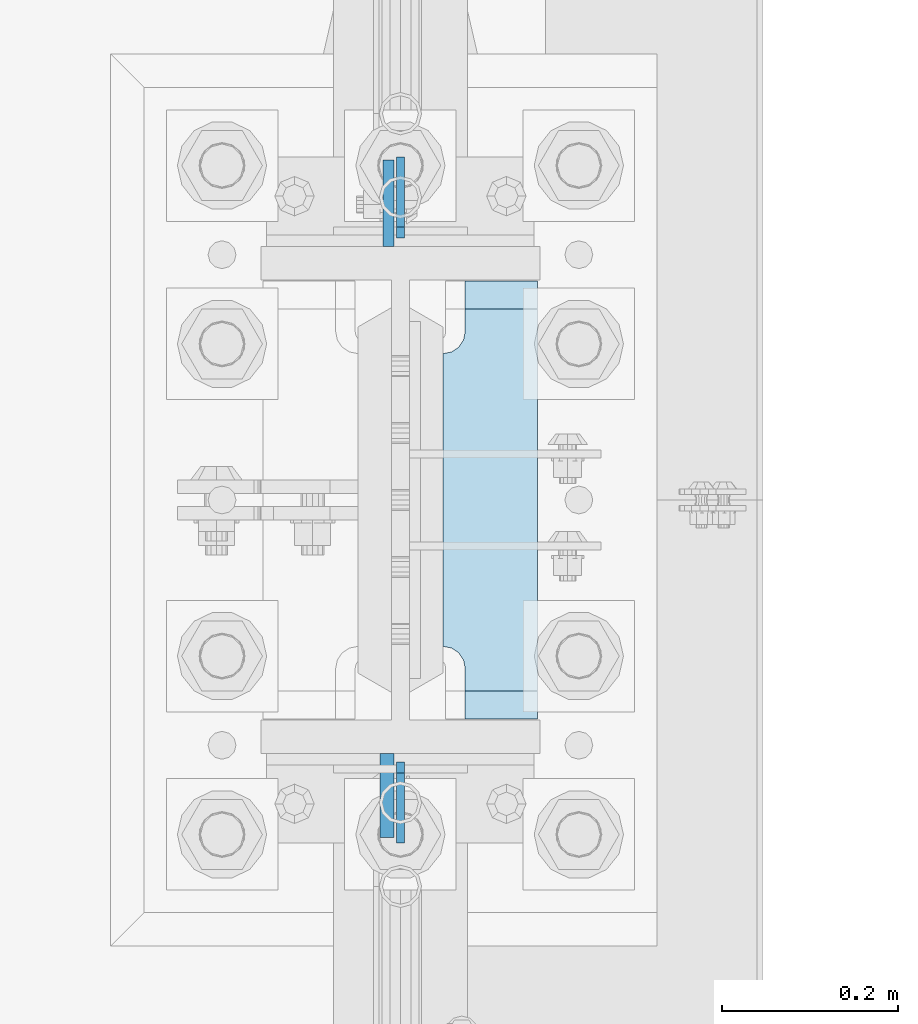
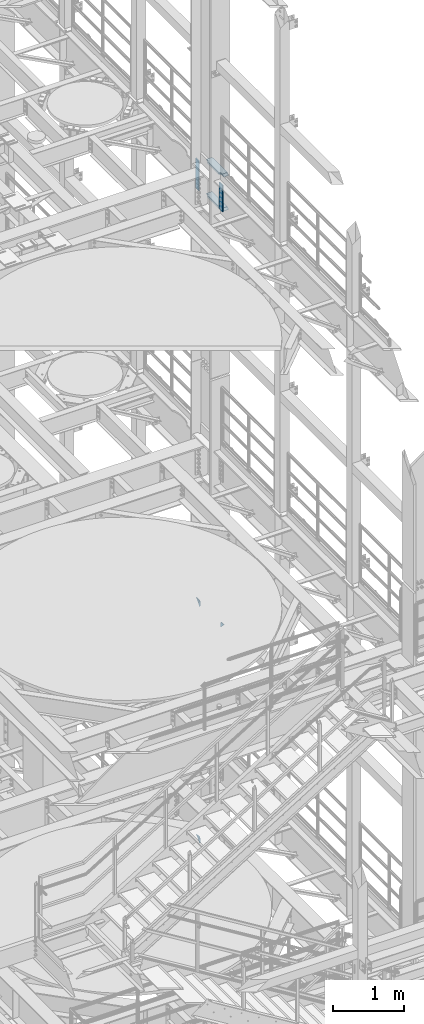
# One storey, part 1674 of 1876: 7 plates, 2 elements without a shape of their own.
"""IFC2X3 building model written with IfcOpenShell, lengths in millimetres."""

from ifc_helpers import new_model, si_unit, frame, origin_with_axes, place, context, subcontext, project, spatial, faceted_brep, material, type_object, element, aggregate, save


model = new_model("IFC2X3")

# Units and contexts
model_context = context("Model", 3, precision=1e-05, world=origin_with_axes())
body_context = subcontext(model_context, "Body", "Model", "MODEL_VIEW")
ifc_project = project(units=[si_unit("LENGTHUNIT", "METRE", prefix="MILLI"), si_unit("AREAUNIT", "SQUARE_METRE"), si_unit("VOLUMEUNIT", "CUBIC_METRE"), si_unit("MASSUNIT", "GRAM", prefix="KILO"), si_unit("TIMEUNIT", "SECOND"), si_unit("PLANEANGLEUNIT", "RADIAN"), si_unit("SOLIDANGLEUNIT", "STERADIAN"), si_unit("THERMODYNAMICTEMPERATUREUNIT", "DEGREE_CELSIUS"), si_unit("LUMINOUSINTENSITYUNIT", "LUMEN")], contexts=[model_context])

# Site, building, storey
site_placement = place(None, origin_with_axes())
site = spatial("IfcSite", under=ifc_project, at=site_placement, CompositionType="ELEMENT")
building_placement = place(site_placement, origin_with_axes())
building = spatial("IfcBuilding", under=site, at=building_placement, Name="Undefined", CompositionType="ELEMENT")
storey_placement = place(building_placement, origin_with_axes())
storey = spatial("IfcBuildingStorey", under=building, at=storey_placement, Name="Undefined", CompositionType="ELEMENT", Elevation=0.0)

# Assembly, plates
assembly_1_placement = place(storey_placement, origin_with_axes())
assembly_1 = element("IfcElementAssembly", 1, at=assembly_1_placement, inside=storey, Name="COLUMN", AssemblyPlace="NOTDEFINED", PredefinedType="RIGID_FRAME")
ifc_material_1 = material(Name="STEEL/A36")
plate_type_1 = type_object("IfcPlateType", PredefinedType="NOTDEFINED")
plate_1_placement = place(assembly_1_placement, frame((7620.0, 1133.47499940317, 10325.1), z_axis=(0.0, 0.707106781186548, 0.707106781186548), x_axis=(0.0, 0.707106781186548, -0.707106781186548)))
plate_1 = element("IfcPlate", 2, at=plate_1_placement, type_object=plate_type_1, material=ifc_material_1, Name="PLATE", context=body_context, shape_type="Brep", body=[
    faceted_brep([(0.0, -4.76249999999982, 0.0), (56.1266013136901, -4.76249999997708, 56.1266013135391), (56.1266013136883, 4.76250000002256, 56.1266013135428), (0.0, 4.76249999999982, 0.0), (74.0871132860975, -4.7624999999698, 56.1266013135246), (74.0871132860993, 4.76250000002983, 56.1266013135282), (130.213714599717, -4.76249999994707, -1.30967237055302e-10), (130.213714599715, 4.76250000005257, -1.23691279441118e-10)], [[[0, 1, 2, 3]], [[1, 4, 5, 2]], [[4, 6, 7, 5]], [[6, 0, 3, 7]], [[5, 7, 3, 2]], [[6, 4, 1, 0]]]),
])
plate_2_placement = place(assembly_1_placement, frame((7620.0, 1914.52500059683, 10325.1), z_axis=(0.0, -0.707106781186548, 0.707106781186548), x_axis=(0.0, -0.707106781186548, -0.707106781186548)))
plate_2 = element("IfcPlate", 3, at=plate_2_placement, type_object=plate_type_1, material=ifc_material_1, Name="PLATE", context=body_context, shape_type="Brep", body=[
    faceted_brep([(0.0, -4.76249999999982, 0.0), (56.1266013136901, -4.76249999997708, 56.1266013135391), (56.1266013136883, 4.76250000002256, 56.1266013135428), (0.0, 4.76249999999982, 0.0), (74.0871132860975, -4.7624999999698, 56.1266013135246), (74.0871132860993, 4.76250000002983, 56.1266013135282), (130.213714599717, -4.76249999994707, -1.30967237055302e-10), (130.213714599715, 4.76250000005257, -1.23691279441118e-10)], [[[0, 1, 2, 3]], [[1, 4, 5, 2]], [[4, 6, 7, 5]], [[6, 0, 3, 7]], [[5, 7, 3, 2]], [[6, 4, 1, 0]]]),
])
plate_3_placement = place(assembly_1_placement, frame((7620.0, 1914.52500059683, 6235.7), z_axis=(0.0, -0.707106781186548, 0.707106781186548), x_axis=(0.0, -0.707106781186548, -0.707106781186548)))
plate_3 = element("IfcPlate", 4, at=plate_3_placement, type_object=plate_type_1, material=ifc_material_1, Name="PLATE", context=body_context, shape_type="Brep", body=[
    faceted_brep([(0.0, -4.76249999999982, 0.0), (56.1266013136901, -4.76249999997708, 56.1266013135391), (56.1266013136883, 4.76250000002256, 56.1266013135428), (0.0, 4.76249999999982, 0.0), (74.0871132860975, -4.7624999999698, 56.1266013135246), (74.0871132860993, 4.76250000002983, 56.1266013135282), (130.213714599717, -4.76249999994707, -1.30967237055302e-10), (130.213714599715, 4.76250000005257, -1.23691279441118e-10)], [[[0, 1, 2, 3]], [[1, 4, 5, 2]], [[4, 6, 7, 5]], [[6, 0, 3, 7]], [[5, 7, 3, 2]], [[6, 4, 1, 0]]]),
])
aggregate(assembly_1, [plate_1, plate_2, plate_3])

assembly_2_placement = place(storey_placement, origin_with_axes())
assembly_2 = element("IfcElementAssembly", 5, at=assembly_2_placement, inside=storey, Name="COLUMN", AssemblyPlace="NOTDEFINED", PredefinedType="RIGID_FRAME")
ifc_material_2 = material(Name="STEEL/A572-50")
plate_type_2 = type_object("IfcPlateType", PredefinedType="NOTDEFINED")
plate_4_placement = place(assembly_2_placement, frame((7606.50699987411, 1812.925, 17929.225), z_axis=(0.0, 1.0, 0.0), x_axis=(0.0, 0.0, -1.0)))
plate_4 = element("IfcPlate", 6, at=plate_4_placement, type_object=plate_type_2, material=ifc_material_2, Name="PLATE", context=body_context, shape_type="Brep", body=[
    faceted_brep([(0.0, -6.35000000000036, 0.0), (0.0, -6.34999999999991, 98.4250030517578), (0.0, 6.34999999999991, 98.4250030517578), (0.0, 6.35000000000036, 0.0), (514.349975585938, -6.35000000000036, 98.4250030517578), (514.349975585938, 6.35000000000036, 98.4250030517578), (514.349975585938, -6.35000000000036, 0.0), (514.349975585938, 6.35000000000036, 0.0)], [[[0, 1, 2, 3]], [[1, 4, 5, 2]], [[4, 6, 7, 5]], [[6, 0, 3, 7]], [[5, 7, 3, 2]], [[6, 4, 1, 0]]]),
])
plate_type_3 = type_object("IfcPlateType", PredefinedType="NOTDEFINED")
plate_5_placement = place(assembly_2_placement, frame((7604.91949987411, 1235.075, 17919.7), z_axis=(0.0, -1.0, 0.0), x_axis=(0.0, 0.0, -1.0)))
plate_5 = element("IfcPlate", 7, at=plate_5_placement, type_object=plate_type_3, material=ifc_material_2, Name="PLATE", context=body_context, shape_type="Brep", body=[
    faceted_brep([(0.0, -7.9375, 0.0), (0.0, -7.9375, 95.25), (0.0, 7.9375, 95.25), (0.0, 7.9375, 0.0), (457.200012207031, -7.9375, 95.25), (457.200012207031, 7.9375, 95.25), (457.200012207031, -7.9375, 0.0), (457.200012207031, 7.9375, 0.0)], [[[0, 1, 2, 3]], [[1, 4, 5, 2]], [[4, 6, 7, 5]], [[6, 0, 3, 7]], [[5, 7, 3, 2]], [[6, 4, 1, 0]]]),
])
plate_type_4 = type_object("IfcPlateType", PredefinedType="NOTDEFINED")
plate_6_placement = place(assembly_2_placement, frame((7668.41875, 1773.2375, 17376.775012207), z_axis=(0.0, -1.0, 0.0), x_axis=(1.0, 0.0, 0.0)))
plate_6 = element("IfcPlate", 8, at=plate_6_placement, type_object=plate_type_4, material=ifc_material_2, Name="PLATE", context=body_context, shape_type="Brep", body=[
    faceted_brep([(107.949996948242, -15.875, 498.475006103516), (107.949996948242, 15.875, 467.025007631571), (25.3999996185303, 15.875, 467.025007631571), (25.3999996185303, -15.875, 498.475006103516), (23.4665397733561, -15.875, 431.604843634198), (25.3999996185303, -15.875, 441.325002670288), (25.3999996185303, 15.875, 441.325002670288), (23.4665397733561, 15.875, 431.604843634198), (17.9605119724001, -15.875, 423.36449069789), (17.9605119724001, 15.875, 423.36449069789), (9.72015903609281, -15.875, 417.858462896934), (9.72015903609281, 15.875, 417.858462896934), (0.0, -15.875, 415.925003051758), (0.0, 15.875, 415.925003051758), (0.0, -15.875, 82.5500030517578), (0.0, 15.875, 82.5500030517578), (9.72015903609099, -15.875, 80.616543206582), (9.72015903609099, 15.875, 80.616543206582), (17.9605119723983, -15.875, 75.1105154056258), (17.9605119723983, 15.875, 75.1105154056258), (23.4665397733552, -15.875, 66.8701624693183), (23.4665397733552, 15.875, 66.8701624693183), (25.3999996185303, -15.875, 57.1500034332275), (25.3999996185303, 15.875, 57.1500034332275), (25.3999996185303, 15.875, 31.449998471945), (25.3999996185303, -15.875, 0.0), (107.949996948242, 15.875, 31.449998471945), (107.949996948242, -15.875, 0.0)], [[[0, 1, 2, 3]], [[4, 5, 6, 7]], [[8, 4, 7, 9]], [[10, 8, 9, 11]], [[12, 10, 11, 13]], [[14, 12, 13, 15]], [[16, 14, 15, 17]], [[18, 16, 17, 19]], [[20, 18, 19, 21]], [[22, 20, 21, 23]], [[22, 23, 24, 25]], [[26, 27, 25, 24]], [[5, 4, 8, 10, 12, 14, 16, 18, 20, 22, 25, 27, 0, 3]], [[6, 5, 3, 2]], [[26, 24, 23, 21, 19, 17, 15, 13, 11, 9, 7, 6, 2, 1]], [[27, 26, 1, 0]]]),
])
plate_7_placement = place(assembly_2_placement, frame((7668.41875, 1773.2375, 17967.325), z_axis=(0.0, -1.0, 0.0), x_axis=(1.0, 0.0, 0.0)))
plate_7 = element("IfcPlate", 9, at=plate_7_placement, type_object=plate_type_4, material=ifc_material_2, Name="PLATE", context=body_context, shape_type="Brep", body=[
    faceted_brep([(107.949996948242, -15.875, 498.475006103516), (107.949996948242, 15.875, 467.025007631571), (25.3999996185303, 15.875, 467.025007631571), (25.3999996185303, -15.875, 498.475006103516), (23.4665397733561, -15.875, 431.604843634198), (25.3999996185303, -15.875, 441.325002670288), (25.3999996185303, 15.875, 441.325002670288), (23.4665397733561, 15.875, 431.604843634198), (17.9605119724001, -15.875, 423.36449069789), (17.9605119724001, 15.875, 423.36449069789), (9.72015903609281, -15.875, 417.858462896934), (9.72015903609281, 15.875, 417.858462896934), (0.0, -15.875, 415.925003051758), (0.0, 15.875, 415.925003051758), (0.0, -15.875, 82.5500030517578), (0.0, 15.875, 82.5500030517578), (9.72015903609099, -15.875, 80.616543206582), (9.72015903609099, 15.875, 80.616543206582), (17.9605119723983, -15.875, 75.1105154056258), (17.9605119723983, 15.875, 75.1105154056258), (23.4665397733552, -15.875, 66.8701624693183), (23.4665397733552, 15.875, 66.8701624693183), (25.3999996185303, -15.875, 57.1500034332275), (25.3999996185303, 15.875, 57.1500034332275), (25.3999996185303, 15.875, 31.449998471945), (25.3999996185303, -15.875, 0.0), (107.949996948242, 15.875, 31.449998471945), (107.949996948242, -15.875, 0.0)], [[[0, 1, 2, 3]], [[4, 5, 6, 7]], [[8, 4, 7, 9]], [[10, 8, 9, 11]], [[12, 10, 11, 13]], [[14, 12, 13, 15]], [[16, 14, 15, 17]], [[18, 16, 17, 19]], [[20, 18, 19, 21]], [[22, 20, 21, 23]], [[22, 23, 24, 25]], [[26, 27, 25, 24]], [[5, 4, 8, 10, 12, 14, 16, 18, 20, 22, 25, 27, 0, 3]], [[6, 5, 3, 2]], [[26, 24, 23, 21, 19, 17, 15, 13, 11, 9, 7, 6, 2, 1]], [[27, 26, 1, 0]]]),
])
aggregate(assembly_2, [plate_4, plate_5, plate_6, plate_7])

save(model, "model.ifc")
